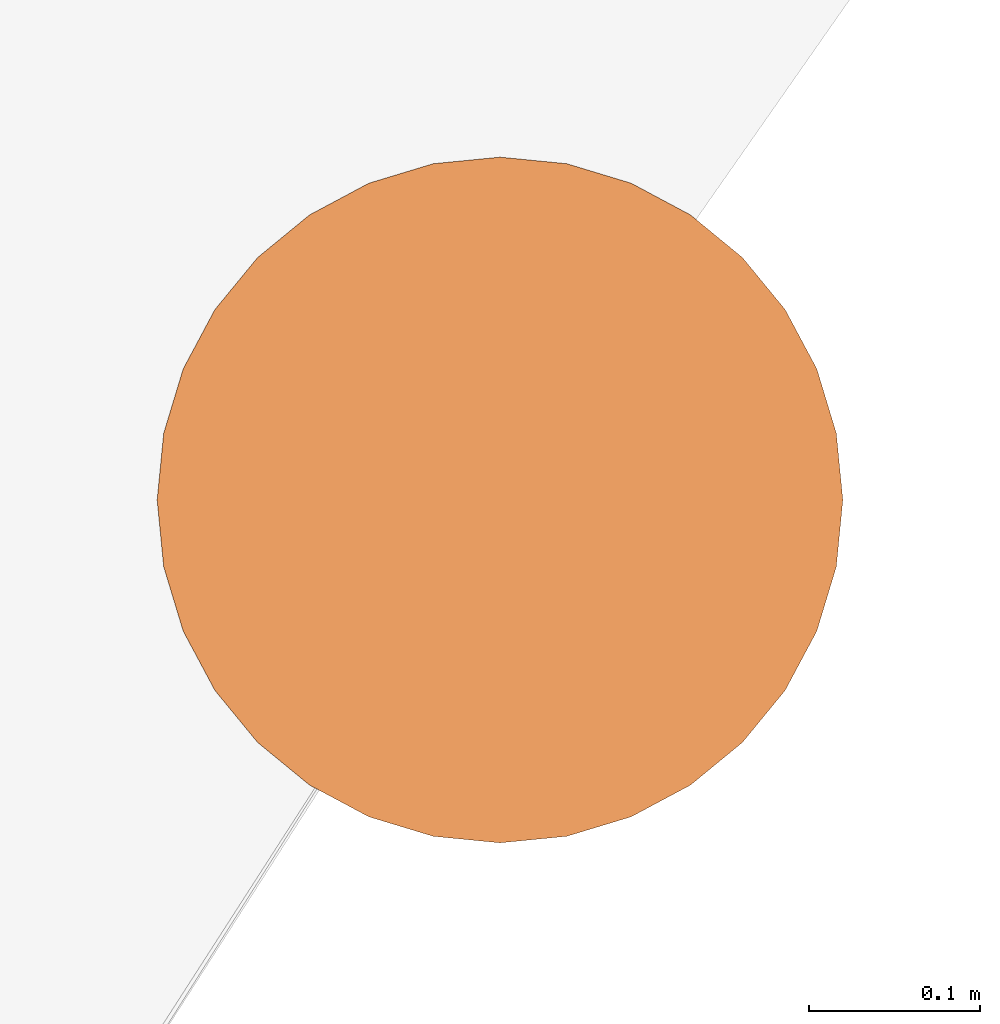
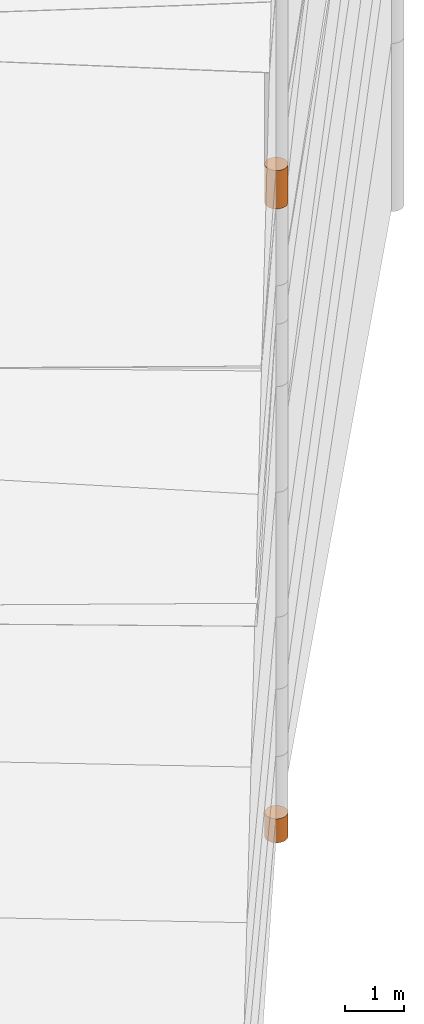
# One storey, part 24 of 24: 2 geographic elements.
"""IFC4 building model written with IfcOpenShell, lengths in metres."""

from ifc_helpers import new_model, entity, si_unit, converted_unit, frame, origin_with_axes, origin_2d_with_axis, place, context, subcontext, project, spatial, polygons, element, save


model = new_model("IFC4")

# Units and contexts
model_context = context("Model", 3, precision=1e-05, world=origin_with_axes())
plan_context = context("Plan", 2, precision=1e-05, world=origin_2d_with_axis())
body_context = subcontext(model_context, "Body", "Model", "MODEL_VIEW")
ifc_project = project(units=[converted_unit("PLANEANGLEUNIT", "degree", entity("IfcReal", 0.0174532925199433), si_unit("PLANEANGLEUNIT", "RADIAN"), dimensions=[0, 0, 0, 0, 0, 0, 0]), si_unit("AREAUNIT", "SQUARE_METRE"), si_unit("VOLUMEUNIT", "CUBIC_METRE"), si_unit("LENGTHUNIT", "METRE")], contexts=[model_context, plan_context])

# Site, building, storey
site_placement = place(None, origin_with_axes())
site = spatial("IfcSite", under=ifc_project, at=site_placement)
building_placement = place(site_placement, origin_with_axes())
building = spatial("IfcBuilding", under=site, at=building_placement, Name="Building")
storey_placement = place(building_placement, origin_with_axes())
storey = spatial("IfcBuildingStorey", under=building, at=storey_placement, Name="Storey")

# Geographic elements
geographic_element_1_placement = place(storey_placement, frame((36.5, 56.7999992370605, 3.60000038146973), z_axis=(0.0, 0.0, 1.0), x_axis=(1.0, 0.0, 0.0)))
element("IfcGeographicElement", 1, at=geographic_element_1_placement, inside=storey, PredefinedType="NOTDEFINED", context=body_context, shape_type="Tessellation", body=[
    polygons([(0.0, 0.0, -0.399999976158142), (0.0390180610120296, 0.196157038211823, -0.399999976158142), (0.0, 0.199999988079071, -0.399999976158142), (0.0, 0.0, 0.399999976158142), (0.0, 0.199999988079071, 0.399999976158142), (0.0390180610120296, 0.196157038211823, 0.399999976158142), (0.0765366926789284, 0.18477588891983, -0.399999976158142), (0.0765366926789284, 0.18477588891983, 0.399999976158142), (0.111114047467709, 0.166293919086456, -0.399999976158142), (0.111114047467709, 0.166293919086456, 0.399999976158142), (0.141421362757683, 0.141421362757683, -0.399999976158142), (0.141421362757683, 0.141421362757683, 0.399999976158142), (0.166293919086456, 0.111114047467709, -0.399999976158142), (0.166293919086456, 0.111114047467709, 0.399999976158142), (0.18477588891983, 0.0765366926789284, -0.399999976158142), (0.18477588891983, 0.0765366926789284, 0.399999976158142), (0.196157038211823, 0.0390180610120296, -0.399999976158142), (0.196157038211823, 0.0390180610120296, 0.399999976158142), (0.199999988079071, 0.0, -0.399999976158142), (0.199999988079071, 0.0, 0.399999976158142), (0.196157038211823, -0.0390180610120296, -0.399999976158142), (0.196157038211823, -0.0390180610120296, 0.399999976158142), (0.18477588891983, -0.0765366926789284, -0.399999976158142), (0.18477588891983, -0.0765366926789284, 0.399999976158142), (0.166293919086456, -0.111114047467709, -0.399999976158142), (0.166293919086456, -0.111114047467709, 0.399999976158142), (0.141421362757683, -0.141421362757683, -0.399999976158142), (0.141421362757683, -0.141421362757683, 0.399999976158142), (0.111114047467709, -0.166293919086456, -0.399999976158142), (0.111114047467709, -0.166293919086456, 0.399999976158142), (0.0765366926789284, -0.18477588891983, -0.399999976158142), (0.0765366926789284, -0.18477588891983, 0.399999976158142), (0.0390180610120296, -0.196157038211823, -0.399999976158142), (0.0390180610120296, -0.196157038211823, 0.399999976158142), (0.0, -0.199999988079071, -0.399999976158142), (0.0, -0.199999988079071, 0.399999976158142), (-0.0390180610120296, -0.196157038211823, -0.399999976158142), (-0.0390180610120296, -0.196157038211823, 0.399999976158142), (-0.0765366926789284, -0.18477588891983, -0.399999976158142), (-0.0765366926789284, -0.18477588891983, 0.399999976158142), (-0.111114047467709, -0.166293919086456, -0.399999976158142), (-0.111114047467709, -0.166293919086456, 0.399999976158142), (-0.141421362757683, -0.141421362757683, -0.399999976158142), (-0.141421362757683, -0.141421362757683, 0.399999976158142), (-0.166293919086456, -0.111114047467709, -0.399999976158142), (-0.166293919086456, -0.111114047467709, 0.399999976158142), (-0.18477588891983, -0.0765366926789284, -0.399999976158142), (-0.18477588891983, -0.0765366926789284, 0.399999976158142), (-0.196157038211823, -0.0390180610120296, -0.399999976158142), (-0.196157038211823, -0.0390180610120296, 0.399999976158142), (-0.199999988079071, 0.0, -0.399999976158142), (-0.199999988079071, 0.0, 0.399999976158142), (-0.196157038211823, 0.0390180610120296, -0.399999976158142), (-0.196157038211823, 0.0390180610120296, 0.399999976158142), (-0.18477588891983, 0.0765366926789284, -0.399999976158142), (-0.18477588891983, 0.0765366926789284, 0.399999976158142), (-0.166293919086456, 0.111114047467709, -0.399999976158142), (-0.166293919086456, 0.111114047467709, 0.399999976158142), (-0.141421362757683, 0.141421362757683, -0.399999976158142), (-0.141421362757683, 0.141421362757683, 0.399999976158142), (-0.111114047467709, 0.166293919086456, -0.399999976158142), (-0.111114047467709, 0.166293919086456, 0.399999976158142), (-0.0765366926789284, 0.18477588891983, -0.399999976158142), (-0.0765366926789284, 0.18477588891983, 0.399999976158142), (-0.0390180610120296, 0.196157038211823, -0.399999976158142), (-0.0390180610120296, 0.196157038211823, 0.399999976158142)], [[[3, 2, 1]], [[6, 5, 4]], [[60, 62, 61, 59]], [[2, 7, 1]], [[8, 6, 4]], [[64, 66, 65, 63]], [[7, 9, 1]], [[10, 8, 4]], [[10, 12, 11, 9]], [[9, 11, 1]], [[12, 10, 4]], [[11, 13, 1]], [[12, 4, 14]], [[38, 40, 39, 37]], [[1, 13, 15]], [[14, 4, 16]], [[44, 46, 45, 43]], [[1, 15, 17]], [[4, 18, 16]], [[14, 16, 15, 13]], [[1, 17, 19]], [[4, 20, 18]], [[40, 42, 41, 39]], [[1, 19, 21]], [[4, 22, 20]], [[50, 52, 51, 49]], [[1, 21, 23]], [[4, 24, 22]], [[20, 22, 21, 19]], [[1, 23, 25]], [[24, 4, 26]], [[52, 54, 53, 51]], [[27, 1, 25]], [[26, 4, 28]], [[58, 60, 59, 57]], [[1, 27, 29]], [[28, 4, 30]], [[26, 28, 27, 25]], [[1, 29, 31]], [[4, 32, 30]], [[5, 6, 2, 3]], [[1, 31, 33]], [[4, 34, 32]], [[6, 8, 7, 2]], [[1, 33, 35]], [[4, 36, 34]], [[8, 10, 9, 7]], [[1, 35, 37]], [[4, 38, 36]], [[66, 5, 3, 65]], [[1, 37, 39]], [[4, 40, 38]], [[36, 38, 37, 35]], [[1, 39, 41]], [[4, 42, 40]], [[46, 48, 47, 45]], [[43, 1, 41]], [[4, 44, 42]], [[32, 34, 33, 31]], [[45, 1, 43]], [[46, 44, 4]], [[34, 36, 35, 33]], [[47, 1, 45]], [[4, 48, 46]], [[16, 18, 17, 15]], [[47, 49, 1]], [[50, 48, 4]], [[18, 20, 19, 17]], [[49, 51, 1]], [[52, 50, 4]], [[48, 50, 49, 47]], [[51, 53, 1]], [[54, 52, 4]], [[22, 24, 23, 21]], [[53, 55, 1]], [[56, 54, 4]], [[24, 26, 25, 23]], [[57, 1, 55]], [[4, 58, 56]], [[54, 56, 55, 53]], [[57, 59, 1]], [[60, 58, 4]], [[56, 58, 57, 55]], [[59, 61, 1]], [[62, 60, 4]], [[28, 30, 29, 27]], [[61, 63, 1]], [[64, 62, 4]], [[30, 32, 31, 29]], [[63, 65, 1]], [[66, 64, 4]], [[62, 64, 63, 61]], [[65, 3, 1]], [[5, 66, 4]], [[42, 44, 43, 41]], [[12, 14, 13, 11]]]),
])
geographic_element_2_placement = place(storey_placement, frame((36.5, 56.7999992370605, -9.75), z_axis=(0.0, 0.0, 1.0), x_axis=(1.0, 0.0, 0.0)))
element("IfcGeographicElement", 2, at=geographic_element_2_placement, inside=storey, PredefinedType="NOTDEFINED", context=body_context, shape_type="Tessellation", body=[
    polygons([(0.0, 0.0, -0.249999985098839), (0.0390180610120296, 0.196157038211823, -0.249999985098839), (0.0, 0.199999988079071, -0.249999985098839), (0.0, 0.0, 0.249999985098839), (0.0, 0.199999988079071, 0.249999985098839), (0.0390180610120296, 0.196157038211823, 0.249999985098839), (0.0765366926789284, 0.18477588891983, -0.249999985098839), (0.0765366926789284, 0.18477588891983, 0.249999985098839), (0.111114047467709, 0.166293919086456, -0.249999985098839), (0.111114047467709, 0.166293919086456, 0.249999985098839), (0.141421362757683, 0.141421362757683, -0.249999985098839), (0.141421362757683, 0.141421362757683, 0.249999985098839), (0.166293919086456, 0.111114047467709, -0.249999985098839), (0.166293919086456, 0.111114047467709, 0.249999985098839), (0.18477588891983, 0.0765366926789284, -0.249999985098839), (0.18477588891983, 0.0765366926789284, 0.249999985098839), (0.196157038211823, 0.0390180610120296, -0.249999985098839), (0.196157038211823, 0.0390180610120296, 0.249999985098839), (0.199999988079071, 0.0, -0.249999985098839), (0.199999988079071, 0.0, 0.249999985098839), (0.196157038211823, -0.0390180610120296, -0.249999985098839), (0.196157038211823, -0.0390180610120296, 0.249999985098839), (0.18477588891983, -0.0765366926789284, -0.249999985098839), (0.18477588891983, -0.0765366926789284, 0.249999985098839), (0.166293919086456, -0.111114047467709, -0.249999985098839), (0.166293919086456, -0.111114047467709, 0.249999985098839), (0.141421362757683, -0.141421362757683, -0.249999985098839), (0.141421362757683, -0.141421362757683, 0.249999985098839), (0.111114047467709, -0.166293919086456, -0.249999985098839), (0.111114047467709, -0.166293919086456, 0.249999985098839), (0.0765366926789284, -0.18477588891983, -0.249999985098839), (0.0765366926789284, -0.18477588891983, 0.249999985098839), (0.0390180610120296, -0.196157038211823, -0.249999985098839), (0.0390180610120296, -0.196157038211823, 0.249999985098839), (0.0, -0.199999988079071, -0.249999985098839), (0.0, -0.199999988079071, 0.249999985098839), (-0.0390180610120296, -0.196157038211823, -0.249999985098839), (-0.0390180610120296, -0.196157038211823, 0.249999985098839), (-0.0765366926789284, -0.18477588891983, -0.249999985098839), (-0.0765366926789284, -0.18477588891983, 0.249999985098839), (-0.111114047467709, -0.166293919086456, -0.249999985098839), (-0.111114047467709, -0.166293919086456, 0.249999985098839), (-0.141421362757683, -0.141421362757683, -0.249999985098839), (-0.141421362757683, -0.141421362757683, 0.249999985098839), (-0.166293919086456, -0.111114047467709, -0.249999985098839), (-0.166293919086456, -0.111114047467709, 0.249999985098839), (-0.18477588891983, -0.0765366926789284, -0.249999985098839), (-0.18477588891983, -0.0765366926789284, 0.249999985098839), (-0.196157038211823, -0.0390180610120296, -0.249999985098839), (-0.196157038211823, -0.0390180610120296, 0.249999985098839), (-0.199999988079071, 0.0, -0.249999985098839), (-0.199999988079071, 0.0, 0.249999985098839), (-0.196157038211823, 0.0390180610120296, -0.249999985098839), (-0.196157038211823, 0.0390180610120296, 0.249999985098839), (-0.18477588891983, 0.0765366926789284, -0.249999985098839), (-0.18477588891983, 0.0765366926789284, 0.249999985098839), (-0.166293919086456, 0.111114047467709, -0.249999985098839), (-0.166293919086456, 0.111114047467709, 0.249999985098839), (-0.141421362757683, 0.141421362757683, -0.249999985098839), (-0.141421362757683, 0.141421362757683, 0.249999985098839), (-0.111114047467709, 0.166293919086456, -0.249999985098839), (-0.111114047467709, 0.166293919086456, 0.249999985098839), (-0.0765366926789284, 0.18477588891983, -0.249999985098839), (-0.0765366926789284, 0.18477588891983, 0.249999985098839), (-0.0390180610120296, 0.196157038211823, -0.249999985098839), (-0.0390180610120296, 0.196157038211823, 0.249999985098839)], [[[3, 2, 1]], [[6, 5, 4]], [[28, 30, 29, 27]], [[2, 7, 1]], [[8, 6, 4]], [[64, 66, 65, 63]], [[7, 9, 1]], [[10, 8, 4]], [[9, 11, 1]], [[12, 10, 4]], [[6, 8, 7, 2]], [[1, 11, 13]], [[12, 4, 14]], [[66, 5, 3, 65]], [[1, 13, 15]], [[4, 16, 14]], [[12, 14, 13, 11]], [[1, 15, 17]], [[16, 4, 18]], [[14, 16, 15, 13]], [[1, 17, 19]], [[4, 20, 18]], [[16, 18, 17, 15]], [[1, 19, 21]], [[20, 4, 22]], [[18, 20, 19, 17]], [[1, 21, 23]], [[22, 4, 24]], [[20, 22, 21, 19]], [[1, 23, 25]], [[24, 4, 26]], [[22, 24, 23, 21]], [[27, 1, 25]], [[4, 28, 26]], [[24, 26, 25, 23]], [[1, 27, 29]], [[28, 4, 30]], [[26, 28, 27, 25]], [[1, 29, 31]], [[4, 32, 30]], [[5, 6, 2, 3]], [[1, 31, 33]], [[4, 34, 32]], [[30, 32, 31, 29]], [[1, 33, 35]], [[4, 36, 34]], [[8, 10, 9, 7]], [[1, 35, 37]], [[4, 38, 36]], [[32, 34, 33, 31]], [[1, 37, 39]], [[4, 40, 38]], [[36, 38, 37, 35]], [[1, 39, 41]], [[4, 42, 40]], [[38, 40, 39, 37]], [[43, 1, 41]], [[4, 44, 42]], [[40, 42, 41, 39]], [[43, 45, 1]], [[46, 44, 4]], [[42, 44, 43, 41]], [[47, 1, 45]], [[48, 46, 4]], [[44, 46, 45, 43]], [[49, 1, 47]], [[4, 50, 48]], [[46, 48, 47, 45]], [[51, 1, 49]], [[52, 50, 4]], [[48, 50, 49, 47]], [[51, 53, 1]], [[4, 54, 52]], [[50, 52, 51, 49]], [[55, 1, 53]], [[4, 56, 54]], [[52, 54, 53, 51]], [[55, 57, 1]], [[4, 58, 56]], [[54, 56, 55, 53]], [[57, 59, 1]], [[60, 58, 4]], [[56, 58, 57, 55]], [[59, 61, 1]], [[62, 60, 4]], [[58, 60, 59, 57]], [[61, 63, 1]], [[64, 62, 4]], [[60, 62, 61, 59]], [[63, 65, 1]], [[66, 64, 4]], [[62, 64, 63, 61]], [[65, 3, 1]], [[5, 66, 4]], [[34, 36, 35, 33]], [[10, 12, 11, 9]]]),
])

save(model, "model.ifc")
